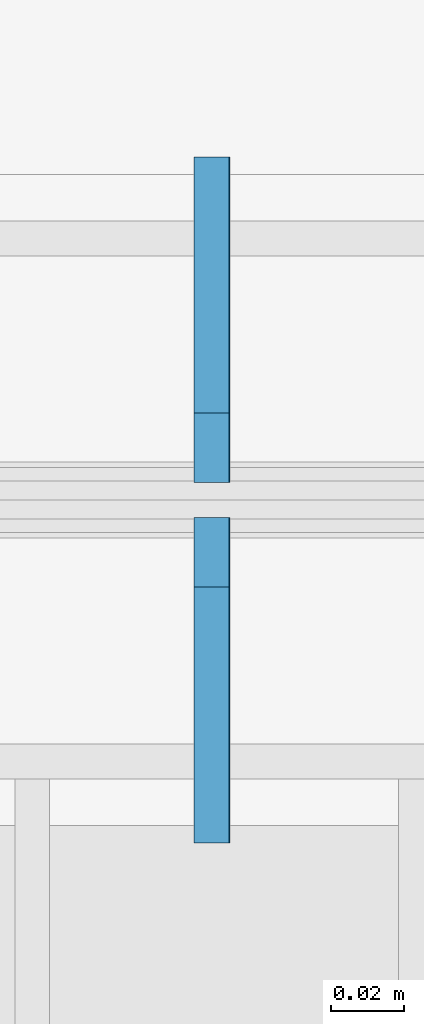
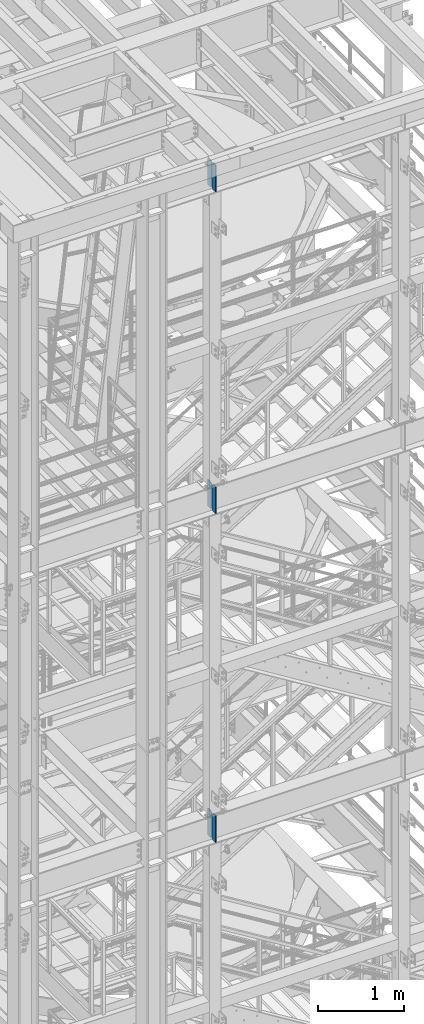
# One storey, part 1433 of 1876: 6 plates, 3 elements without a shape of their own.
"""IFC2X3 building model written with IfcOpenShell, lengths in millimetres."""

from ifc_helpers import new_model, si_unit, frame, origin_with_axes, place, context, subcontext, project, spatial, faceted_brep, material, type_object, element, aggregate, save


model = new_model("IFC2X3")

# Units and contexts
model_context = context("Model", 3, precision=1e-05, world=origin_with_axes())
body_context = subcontext(model_context, "Body", "Model", "MODEL_VIEW")
ifc_project = project(units=[si_unit("LENGTHUNIT", "METRE", prefix="MILLI"), si_unit("AREAUNIT", "SQUARE_METRE"), si_unit("VOLUMEUNIT", "CUBIC_METRE"), si_unit("MASSUNIT", "GRAM", prefix="KILO"), si_unit("TIMEUNIT", "SECOND"), si_unit("PLANEANGLEUNIT", "RADIAN"), si_unit("SOLIDANGLEUNIT", "STERADIAN"), si_unit("THERMODYNAMICTEMPERATUREUNIT", "DEGREE_CELSIUS"), si_unit("LUMINOUSINTENSITYUNIT", "LUMEN")], contexts=[model_context])

# Site, building, storey
site_placement = place(None, origin_with_axes())
site = spatial("IfcSite", under=ifc_project, at=site_placement, CompositionType="ELEMENT")
building_placement = place(site_placement, origin_with_axes())
building = spatial("IfcBuilding", under=site, at=building_placement, Name="Undefined", CompositionType="ELEMENT")
storey_placement = place(building_placement, origin_with_axes())
storey = spatial("IfcBuildingStorey", under=building, at=storey_placement, Name="Undefined", CompositionType="ELEMENT", Elevation=0.0)

# Assembly, plates
assembly_1_placement = place(storey_placement, origin_with_axes())
assembly_1 = element("IfcElementAssembly", 1, at=assembly_1_placement, inside=storey, Name="BEAM", AssemblyPlace="NOTDEFINED", PredefinedType="RIGID_FRAME")
ifc_material = material(Name="STEEL/A36")
plate_type = type_object("IfcPlateType", PredefinedType="NOTDEFINED")
plate_1_placement = place(assembly_1_placement, frame((2539.74997226604, -7205.6625, 22159.9125), z_axis=(0.0, 0.0, 1.0), x_axis=(0.0, 1.0, 0.0)))
plate_1 = element("IfcPlate", 2, at=plate_1_placement, type_object=plate_type, material=ifc_material, Name="PLATE", context=body_context, shape_type="Brep", body=[
    faceted_brep([(0.0, -4.76249999999982, 0.0), (0.0, -4.76250000000073, 381.0), (0.0, 4.76250000000073, 381.0), (0.0, 4.76249999999982, 0.0), (69.8500022888184, -4.76249999999982, 381.0), (69.8500022888184, 4.76249999999982, 381.0), (88.9000015258789, -4.76249999999982, 361.950000762939), (88.9000015258789, 4.76249999999982, 361.950000762939), (88.9000015258789, -4.76249999999982, 19.0499992370605), (88.9000015258789, 4.76249999999982, 19.0499992370605), (69.8500022888184, -4.76249999999982, 0.0), (69.8500022888184, 4.76249999999982, 0.0)], [[[0, 1, 2, 3]], [[1, 4, 5, 2]], [[4, 6, 7, 5]], [[6, 8, 9, 7]], [[8, 10, 11, 9]], [[10, 0, 3, 11]], [[5, 7, 9, 11, 3, 2]], [[10, 8, 6, 4, 1, 0]]]),
])
plate_2_placement = place(assembly_1_placement, frame((2539.74997226604, -7107.2375, 22159.9125), z_axis=(0.0, 0.0, 1.0), x_axis=(0.0, 1.0, 0.0)))
plate_2 = element("IfcPlate", 3, at=plate_2_placement, type_object=plate_type, material=ifc_material, Name="PLATE", context=body_context, shape_type="Brep", body=[
    faceted_brep([(0.0, -4.76249999999982, 19.0499992370605), (0.0, -4.76249999999982, 361.950000762939), (0.0, 4.76249999999982, 361.950000762939), (0.0, 4.76249999999982, 19.0499992370605), (19.0499992370605, -4.76249999999982, 381.0), (19.0499992370605, 4.76249999999982, 381.0), (88.9000015258789, -4.76249999999982, 381.0), (88.9000015258789, 4.76249999999982, 381.0), (88.9000015258789, -4.76249999999982, 0.0), (88.9000015258789, 4.76249999999982, 0.0), (19.0499992370605, -4.76249999999982, 0.0), (19.0499992370605, 4.76249999999982, 0.0)], [[[0, 1, 2, 3]], [[1, 4, 5, 2]], [[4, 6, 7, 5]], [[6, 8, 9, 7]], [[8, 10, 11, 9]], [[10, 0, 3, 11]], [[5, 7, 9, 11, 3, 2]], [[10, 8, 6, 4, 1, 0]]]),
])
aggregate(assembly_1, [plate_1, plate_2])

assembly_2_placement = place(storey_placement, origin_with_axes())
assembly_2 = element("IfcElementAssembly", 4, at=assembly_2_placement, inside=storey, Name="BEAM", AssemblyPlace="NOTDEFINED", PredefinedType="RIGID_FRAME")
plate_3_placement = place(assembly_2_placement, frame((2539.74997226604, -7205.6625, 17587.9125), z_axis=(0.0, 0.0, 1.0), x_axis=(0.0, 1.0, 0.0)))
plate_3 = element("IfcPlate", 5, at=plate_3_placement, type_object=plate_type, material=ifc_material, Name="PLATE", context=body_context, shape_type="Brep", body=[
    faceted_brep([(0.0, -4.76249999999982, 0.0), (0.0, -4.76250000000073, 381.0), (0.0, 4.76250000000073, 381.0), (0.0, 4.76249999999982, 0.0), (69.8500022888184, -4.76249999999982, 381.0), (69.8500022888184, 4.76249999999982, 381.0), (88.9000015258789, -4.76249999999982, 361.950000762939), (88.9000015258789, 4.76249999999982, 361.950000762939), (88.9000015258789, -4.76249999999982, 19.0499992370605), (88.9000015258789, 4.76249999999982, 19.0499992370605), (69.8500022888184, -4.76249999999982, 0.0), (69.8500022888184, 4.76249999999982, 0.0)], [[[0, 1, 2, 3]], [[1, 4, 5, 2]], [[4, 6, 7, 5]], [[6, 8, 9, 7]], [[8, 10, 11, 9]], [[10, 0, 3, 11]], [[5, 7, 9, 11, 3, 2]], [[10, 8, 6, 4, 1, 0]]]),
])
plate_4_placement = place(assembly_2_placement, frame((2539.74997226604, -7107.2375, 17587.9125), z_axis=(0.0, 0.0, 1.0), x_axis=(0.0, 1.0, 0.0)))
plate_4 = element("IfcPlate", 6, at=plate_4_placement, type_object=plate_type, material=ifc_material, Name="PLATE", context=body_context, shape_type="Brep", body=[
    faceted_brep([(0.0, -4.76249999999982, 19.0499992370605), (0.0, -4.76249999999982, 361.950000762939), (0.0, 4.76249999999982, 361.950000762939), (0.0, 4.76249999999982, 19.0499992370605), (19.0499992370605, -4.76249999999982, 381.0), (19.0499992370605, 4.76249999999982, 381.0), (88.9000015258789, -4.76249999999982, 381.0), (88.9000015258789, 4.76249999999982, 381.0), (88.9000015258789, -4.76249999999982, 0.0), (88.9000015258789, 4.76249999999982, 0.0), (19.0499992370605, -4.76249999999982, 0.0), (19.0499992370605, 4.76249999999982, 0.0)], [[[0, 1, 2, 3]], [[1, 4, 5, 2]], [[4, 6, 7, 5]], [[6, 8, 9, 7]], [[8, 10, 11, 9]], [[10, 0, 3, 11]], [[5, 7, 9, 11, 3, 2]], [[10, 8, 6, 4, 1, 0]]]),
])
aggregate(assembly_2, [plate_3, plate_4])

assembly_3_placement = place(storey_placement, origin_with_axes())
assembly_3 = element("IfcElementAssembly", 7, at=assembly_3_placement, inside=storey, Name="BEAM", AssemblyPlace="NOTDEFINED", PredefinedType="RIGID_FRAME")
plate_5_placement = place(assembly_3_placement, frame((2540.0, -7205.6625, 12914.3125), z_axis=(0.0, 0.0, 1.0), x_axis=(0.0, 1.0, 0.0)))
plate_5 = element("IfcPlate", 8, at=plate_5_placement, type_object=plate_type, material=ifc_material, Name="PLATE", context=body_context, shape_type="Brep", body=[
    faceted_brep([(0.0, -4.76249999999982, 0.0), (0.0, -4.76250000000073, 381.0), (0.0, 4.76250000000073, 381.0), (0.0, 4.76249999999982, 0.0), (69.8500022888184, -4.76249999999982, 381.0), (69.8500022888184, 4.76249999999982, 381.0), (88.9000015258789, -4.76249999999982, 361.950000762939), (88.9000015258789, 4.76249999999982, 361.950000762939), (88.9000015258789, -4.76249999999982, 19.0499992370605), (88.9000015258789, 4.76249999999982, 19.0499992370605), (69.8500022888184, -4.76249999999982, 0.0), (69.8500022888184, 4.76249999999982, 0.0)], [[[0, 1, 2, 3]], [[1, 4, 5, 2]], [[4, 6, 7, 5]], [[6, 8, 9, 7]], [[8, 10, 11, 9]], [[10, 0, 3, 11]], [[5, 7, 9, 11, 3, 2]], [[10, 8, 6, 4, 1, 0]]]),
])
plate_6_placement = place(assembly_3_placement, frame((2540.0, -7107.2375, 12914.3125), z_axis=(0.0, 0.0, 1.0), x_axis=(0.0, 1.0, 0.0)))
plate_6 = element("IfcPlate", 9, at=plate_6_placement, type_object=plate_type, material=ifc_material, Name="PLATE", context=body_context, shape_type="Brep", body=[
    faceted_brep([(0.0, -4.76249999999982, 19.0499992370605), (0.0, -4.76249999999982, 361.950000762939), (0.0, 4.76249999999982, 361.950000762939), (0.0, 4.76249999999982, 19.0499992370605), (19.0499992370605, -4.76249999999982, 381.0), (19.0499992370605, 4.76249999999982, 381.0), (88.9000015258789, -4.76249999999982, 381.0), (88.9000015258789, 4.76249999999982, 381.0), (88.9000015258789, -4.76249999999982, 0.0), (88.9000015258789, 4.76249999999982, 0.0), (19.0499992370605, -4.76249999999982, 0.0), (19.0499992370605, 4.76249999999982, 0.0)], [[[0, 1, 2, 3]], [[1, 4, 5, 2]], [[4, 6, 7, 5]], [[6, 8, 9, 7]], [[8, 10, 11, 9]], [[10, 0, 3, 11]], [[5, 7, 9, 11, 3, 2]], [[10, 8, 6, 4, 1, 0]]]),
])
aggregate(assembly_3, [plate_5, plate_6])

save(model, "model.ifc")
